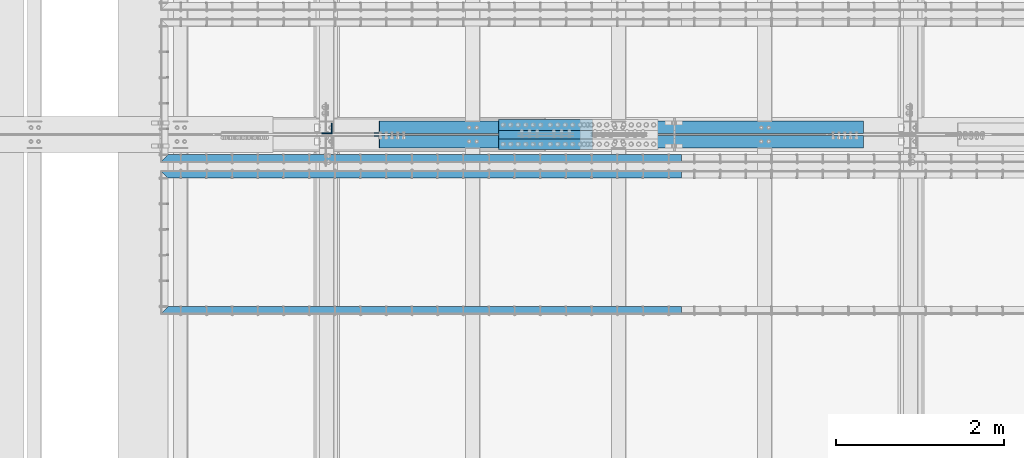
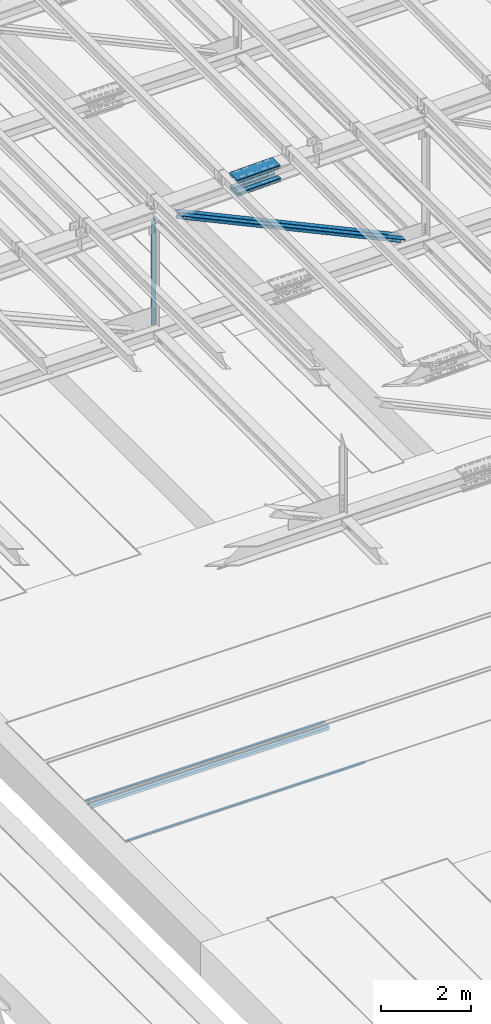
# One storey, part 1848 of 3843: 10 beams, 2 members, 7 elements without a shape of their own.
"""IFC2X3 building model written with IfcOpenShell, lengths in millimetres."""

from ifc_helpers import new_model, si_unit, frame, origin_with_axes, place, context, subcontext, project, spatial, faceted_brep, material, type_object, element, aggregate, save


model = new_model("IFC2X3")

# Units and contexts
model_context = context("Model", 3, precision=1e-05, world=origin_with_axes())
body_context = subcontext(model_context, "Body", "Model", "MODEL_VIEW")
ifc_project = project(units=[si_unit("LENGTHUNIT", "METRE", prefix="MILLI"), si_unit("AREAUNIT", "SQUARE_METRE"), si_unit("VOLUMEUNIT", "CUBIC_METRE"), si_unit("MASSUNIT", "GRAM", prefix="KILO"), si_unit("TIMEUNIT", "SECOND"), si_unit("PLANEANGLEUNIT", "RADIAN"), si_unit("SOLIDANGLEUNIT", "STERADIAN"), si_unit("THERMODYNAMICTEMPERATUREUNIT", "DEGREE_CELSIUS"), si_unit("LUMINOUSINTENSITYUNIT", "LUMEN")], contexts=[model_context])

# Site, building, storey
site_placement = place(None, origin_with_axes())
site = spatial("IfcSite", under=ifc_project, at=site_placement, CompositionType="ELEMENT")
building_placement = place(site_placement, origin_with_axes())
building = spatial("IfcBuilding", under=site, at=building_placement, Name="Undefined", CompositionType="ELEMENT")
storey_placement = place(building_placement, origin_with_axes())
storey = spatial("IfcBuildingStorey", under=building, at=storey_placement, Name="Undefined", CompositionType="ELEMENT", Elevation=0.0)

# Assembly, beam
assembly_1_placement = place(storey_placement, origin_with_axes())
assembly_1 = element("IfcElementAssembly", 1, at=assembly_1_placement, inside=storey, Name="EMBED_ANGLE", AssemblyPlace="NOTDEFINED", PredefinedType="RIGID_FRAME")
ifc_material_1 = material(Name="STEEL/A36")
beam_type_1 = type_object("IfcBeamType", Name="L3-1/2X3-1/2X5/16", PredefinedType="NOTDEFINED")
beam_1_placement = place(assembly_1_placement, frame((53207.412390625, 58632.3439999965, 30410.15), z_axis=(0.0, 0.0, -1.0), x_axis=(-1.0, 0.0, 0.0)))
beam_1 = element("IfcBeam", 2, at=beam_1_placement, type_object=beam_type_1, material=ifc_material_1, Name="EMBED_ANGLE", ObjectType="L3-1/2X3-1/2X5/16", context=body_context, shape_type="Brep", body=[
    faceted_brep([(-3.63797880709171e-12, 44.4499999999971, -44.4500000000007), (-3.63797880709171e-12, 44.4499999999971, 44.4500000000007), (6096.0, 44.4499999999971, 44.4500000000007), (6096.0, 44.4499999999971, -44.4500000000007), (-3.63797880709171e-12, 36.5124999999971, 44.4500000000007), (6103.9375, 36.5124999999971, 44.4500000000007), (-3.63797880709171e-12, 36.5124999999971, -36.5125000000007), (6103.9375, 36.5124999999971, -36.5125000000007), (3.63797880709171e-12, -44.4499999999971, -36.5125000000007), (6184.89999999999, -44.4499999999971, -36.5125000000007), (3.63797880709171e-12, -44.4499999999971, -44.4500000000007), (6184.89999999999, -44.4499999999971, -44.4500000000007)], [[[0, 1, 2, 3]], [[1, 4, 5, 2]], [[4, 6, 7, 5]], [[6, 8, 9, 7]], [[8, 10, 11, 9]], [[10, 0, 3, 11]], [[5, 7, 9, 11, 3, 2]], [[10, 8, 6, 4, 1, 0]]]),
])
aggregate(assembly_1, [beam_1])

assembly_2_placement = place(storey_placement, origin_with_axes())
assembly_2 = element("IfcElementAssembly", 3, at=assembly_2_placement, inside=storey, Name="EMBED_ANGLE", AssemblyPlace="NOTDEFINED", PredefinedType="RIGID_FRAME")
beam_2_placement = place(assembly_2_placement, frame((53207.4119790039, 56829.325, 30410.15), z_axis=(0.0, 0.0, -1.0), x_axis=(-1.0, 0.0, 0.0)))
beam_2 = element("IfcBeam", 4, at=beam_2_placement, type_object=beam_type_1, material=ifc_material_1, Name="EMBED_ANGLE", ObjectType="L3-1/2X3-1/2X5/16", context=body_context, shape_type="Brep", body=[
    faceted_brep([(-3.63797880709171e-12, 44.4499999999971, -44.4500000000007), (-3.63797880709171e-12, 44.4499999999971, 44.4500000000007), (6096.0, 44.4499999999971, 44.4500000000007), (6096.0, 44.4499999999971, -44.4500000000007), (-3.63797880709171e-12, 36.5124999999971, 44.4500000000007), (6103.9375, 36.5124999999971, 44.4500000000007), (-3.63797880709171e-12, 36.5124999999971, -36.5125000000007), (6103.9375, 36.5124999999971, -36.5125000000007), (3.63797880709171e-12, -44.4499999999971, -36.5125000000007), (6184.89999999999, -44.4499999999971, -36.5125000000007), (3.63797880709171e-12, -44.4499999999971, -44.4500000000007), (6184.89999999999, -44.4499999999971, -44.4500000000007)], [[[0, 1, 2, 3]], [[1, 4, 5, 2]], [[4, 6, 7, 5]], [[6, 8, 9, 7]], [[8, 10, 11, 9]], [[10, 0, 3, 11]], [[5, 7, 9, 11, 3, 2]], [[10, 8, 6, 4, 1, 0]]]),
])
aggregate(assembly_2, [beam_2])

assembly_3_placement = place(storey_placement, origin_with_axes())
assembly_3 = element("IfcElementAssembly", 5, at=assembly_3_placement, inside=storey, Name="EMBED_ANGLE", AssemblyPlace="NOTDEFINED", PredefinedType="RIGID_FRAME")
beam_3_placement = place(assembly_3_placement, frame((47022.5119790039, 58442.606, 30410.15), z_axis=(0.0, 0.0, -1.0), x_axis=(1.0, 0.0, 0.0)))
beam_3 = element("IfcBeam", 6, at=beam_3_placement, type_object=beam_type_1, material=ifc_material_1, Name="EMBED_ANGLE", ObjectType="L3-1/2X3-1/2X5/16", context=body_context, shape_type="Brep", body=[
    faceted_brep([(88.8999999971129, 44.4500000000007, -44.4499999999971), (88.8999999965163, 44.4499999999971, 44.4500000000007), (6184.90000000001, 44.4499999999971, 44.4500000000007), (6184.90000000001, 44.4499999999971, -44.4500000000007), (80.9624999965163, 36.5124999999971, 44.4500000000007), (6184.90000000001, 36.5124999999971, 44.4500000000007), (80.9624999971129, 36.5125000000007, -36.5124999999971), (6184.90000000001, 36.5124999999971, -36.5125000000007), (3.63797880709171e-12, -44.4499999999971, -36.5125000000007), (6184.89999999999, -44.4499999999971, -36.5125000000007), (3.63797880709171e-12, -44.4499999999971, -44.4500000000007), (6184.89999999999, -44.4499999999971, -44.4500000000007)], [[[0, 1, 2, 3]], [[1, 4, 5, 2]], [[4, 6, 7, 5]], [[6, 8, 9, 7]], [[8, 10, 11, 9]], [[10, 0, 3, 11]], [[5, 7, 9, 11, 3, 2]], [[10, 8, 6, 4, 1, 0]]]),
])
aggregate(assembly_3, [beam_3])

# Assembly, beams
assembly_4_placement = place(storey_placement, origin_with_axes())
assembly_4 = element("IfcElementAssembly", 7, at=assembly_4_placement, inside=storey, Name="BEAM", AssemblyPlace="NOTDEFINED", PredefinedType="RIGID_FRAME")
ifc_material_2 = material(Name="STEEL/A572-50")
beam_type_2 = type_object("IfcBeamType", PredefinedType="NOTDEFINED")
beam_4_placement = place(assembly_4_placement, frame((51036.3155330324, 59029.6, 45745.1992940111), z_axis=(0.0, -1.0, 0.0), x_axis=(0.999699385122672, 0.0, 0.0245181440030071)))
beam_4 = element("IfcBeam", 8, at=beam_4_placement, type_object=beam_type_2, material=ifc_material_2, Name="PLATE", context=body_context, shape_type="Brep", body=[
    faceted_brep([(-4.36557456851006e-11, 12.7000000000116, -63.5), (-4.36557456851006e-11, 12.7000000000116, 63.5), (1104.90907094938, 12.6999999984037, 63.5), (1104.90907094938, 12.6999999984037, -63.5), (1.45519152283669e-11, -12.700000000008, 63.5), (1104.90907094934, -12.7000000015032, 63.5), (1.45519152283669e-11, -12.700000000008, -63.5), (1104.90907094934, -12.7000000015032, -63.5)], [[[0, 1, 2, 3]], [[1, 4, 5, 2]], [[4, 6, 7, 5]], [[6, 0, 3, 7]], [[5, 7, 3, 2]], [[6, 4, 1, 0]]]),
])
beam_5_placement = place(assembly_4_placement, frame((51036.3155330324, 58801.0, 45745.1992940111), z_axis=(0.0, -1.0, 0.0), x_axis=(0.999699385122672, 0.0, 0.0245181440030071)))
beam_5 = element("IfcBeam", 9, at=beam_5_placement, type_object=beam_type_2, material=ifc_material_2, Name="PLATE", context=body_context, shape_type="Brep", body=[
    faceted_brep([(-4.36557456851006e-11, 12.7000000000116, -63.5), (-4.36557456851006e-11, 12.7000000000116, 63.5), (1104.90907094938, 12.6999999984037, 63.5), (1104.90907094938, 12.6999999984037, -63.5), (1.45519152283669e-11, -12.700000000008, 63.5), (1104.90907094934, -12.7000000015032, 63.5), (1.45519152283669e-11, -12.700000000008, -63.5), (1104.90907094934, -12.7000000015032, -63.5)], [[[0, 1, 2, 3]], [[1, 4, 5, 2]], [[4, 6, 7, 5]], [[6, 0, 3, 7]], [[5, 7, 3, 2]], [[6, 4, 1, 0]]]),
])
beam_6_placement = place(assembly_4_placement, frame((51043.5640563281, 58801.0, 45450.0189870714), z_axis=(0.0, -1.0, 0.0), x_axis=(0.999699385122672, 0.0, 0.0245181440030071)))
beam_6 = element("IfcBeam", 10, at=beam_6_placement, type_object=beam_type_2, material=ifc_material_2, Name="PLATE", context=body_context, shape_type="Brep", body=[
    faceted_brep([(-4.36557456851006e-11, 12.7000000000116, -63.5), (-4.36557456851006e-11, 12.7000000000116, 63.5), (1104.90000001677, 12.7000000017251, 63.5), (1104.90000001677, 12.7000000017251, -63.5), (1.45519152283669e-11, -12.700000000008, 63.5), (1104.90000001682, -12.6999999982909, 63.5), (1.45519152283669e-11, -12.700000000008, -63.5), (1104.90000001682, -12.6999999982909, -63.5)], [[[0, 1, 2, 3]], [[1, 4, 5, 2]], [[4, 6, 7, 5]], [[6, 0, 3, 7]], [[5, 7, 3, 2]], [[6, 4, 1, 0]]]),
])
beam_7_placement = place(assembly_4_placement, frame((51043.5640563281, 59029.6, 45450.0189870714), z_axis=(0.0, -1.0, 0.0), x_axis=(0.999699385122672, 0.0, 0.0245181440030071)))
beam_7 = element("IfcBeam", 11, at=beam_7_placement, type_object=beam_type_2, material=ifc_material_2, Name="PLATE", context=body_context, shape_type="Brep", body=[
    faceted_brep([(-4.36557456851006e-11, 12.7000000000116, -63.5), (-4.36557456851006e-11, 12.7000000000116, 63.5), (1104.90000001677, 12.7000000017251, 63.5), (1104.90000001677, 12.7000000017251, -63.5), (1.45519152283669e-11, -12.700000000008, 63.5), (1104.90000001682, -12.6999999982909, 63.5), (1.45519152283669e-11, -12.700000000008, -63.5), (1104.90000001682, -12.6999999982909, -63.5)], [[[0, 1, 2, 3]], [[1, 4, 5, 2]], [[4, 6, 7, 5]], [[6, 0, 3, 7]], [[5, 7, 3, 2]], [[6, 4, 1, 0]]]),
])
beam_type_3 = type_object("IfcBeamType", PredefinedType="NOTDEFINED")
beam_8_placement = place(assembly_4_placement, frame((52139.372556607, 58915.3, 45834.2616105658), z_axis=(0.0, -1.0, 0.0), x_axis=(-0.999699385122672, 0.0, -0.024518144003004)))
beam_8 = element("IfcBeam", 12, at=beam_8_placement, type_object=beam_type_3, material=ifc_material_2, Name="PLATE", context=body_context, shape_type="Brep", body=[
    faceted_brep([(-1.45519152283669e-11, 12.7000000000025, -177.800000000003), (-1.45519152283669e-11, 12.7000000000025, 177.800000000003), (1104.90000001682, 12.7000000017051, 177.800000000003), (1104.90000001682, 12.7000000017051, -177.800000000003), (4.36557456851006e-11, -12.7000000000171, 177.800000000003), (1104.90000001686, -12.6999999983072, 177.800000000003), (4.36557456851006e-11, -12.7000000000171, -177.800000000003), (1104.90000001686, -12.6999999983072, -177.800000000003)], [[[0, 1, 2, 3]], [[1, 4, 5, 2]], [[4, 6, 7, 5]], [[6, 0, 3, 7]], [[5, 7, 3, 2]], [[6, 4, 1, 0]]]),
])
beam_9_placement = place(assembly_4_placement, frame((52149.6526513255, 58915.3, 45415.215263873), z_axis=(0.0, -1.0, 0.0), x_axis=(-0.999699385122672, 0.0, -0.024518144003004)))
beam_9 = element("IfcBeam", 13, at=beam_9_placement, type_object=beam_type_3, material=ifc_material_2, Name="PLATE", context=body_context, shape_type="Brep", body=[
    faceted_brep([(-1.45519152283669e-11, 12.7000000000025, -177.800000000003), (-1.45519152283669e-11, 12.7000000000025, 177.800000000003), (1104.90000001682, 12.7000000017051, 177.800000000003), (1104.90000001682, 12.7000000017051, -177.800000000003), (4.36557456851006e-11, -12.7000000000171, 177.800000000003), (1104.90000001686, -12.6999999983072, 177.800000000003), (4.36557456851006e-11, -12.7000000000171, -177.800000000003), (1104.90000001686, -12.6999999983072, -177.800000000003)], [[[0, 1, 2, 3]], [[1, 4, 5, 2]], [[4, 6, 7, 5]], [[6, 0, 3, 7]], [[5, 7, 3, 2]], [[6, 4, 1, 0]]]),
])
aggregate(assembly_4, [beam_4, beam_5, beam_6, beam_8, beam_9, beam_7])

# Assembly, beam
assembly_5_placement = place(storey_placement, origin_with_axes())
assembly_5 = element("IfcElementAssembly", 14, at=assembly_5_placement, inside=storey, Name="ANGLE", AssemblyPlace="NOTDEFINED", PredefinedType="RIGID_FRAME")
beam_type_4 = type_object("IfcBeamType", Name="L5X5X3/8", PredefinedType="NOTDEFINED")
beam_10_placement = place(assembly_5_placement, frame((48996.6, 58988.325, 45546.8867572636), z_axis=(-1.0, 0.0, 0.0), x_axis=(0.0, 0.0, -1.0)))
beam_10 = element("IfcBeam", 15, at=beam_10_placement, type_object=beam_type_4, material=ifc_material_2, Name="ANGLE", ObjectType="L5X5X3/8", context=body_context, shape_type="Brep", body=[
    faceted_brep([(223.459240537923, 63.5, -63.5), (223.459240537923, 63.5, 63.5), (3028.1730929709, 63.5, 63.5), (3028.1730929709, 63.5, -63.5), (223.459240537923, 53.9749999999985, 63.5), (3028.1730929709, 53.9749999999985, 63.5), (223.459240537923, 53.9749999999985, -53.9749999999985), (3028.1730929709, 53.9749999999985, -53.9749999999985), (223.459240537923, -63.5, -53.9749999999985), (3028.1730929709, -63.5, -53.9749999999985), (223.459240537923, -63.5, -63.5), (3028.1730929709, -63.5, -63.5)], [[[0, 1, 2, 3]], [[1, 4, 5, 2]], [[4, 6, 7, 5]], [[6, 8, 9, 7]], [[8, 10, 11, 9]], [[10, 0, 3, 11]], [[5, 7, 9, 11, 3, 2]], [[10, 8, 6, 4, 1, 0]]]),
])
aggregate(assembly_5, [beam_10])

# Assembly, member
assembly_6_placement = place(storey_placement, origin_with_axes())
assembly_6 = element("IfcElementAssembly", 16, at=assembly_6_placement, inside=storey, Name="ANGLE", AssemblyPlace="NOTDEFINED", PredefinedType="RIGID_FRAME")
member_type = type_object("IfcMemberType", Name="L6X6X1/2", PredefinedType="NOTDEFINED")
member_1_placement = place(assembly_6_placement, frame((48996.6000000179, 59001.025, 45546.8867572636), z_axis=(-0.420689214779442, 0.0, -0.907204819524376), x_axis=(0.907204819524377, 0.0, -0.420689214779442)))
member_1 = element("IfcMember", 17, at=member_1_placement, type_object=member_type, material=ifc_material_2, Name="ANGLE", ObjectType="L6X6X1/2", context=body_context, shape_type="Brep", body=[
    faceted_brep([(654.73262605285, 76.1999999999971, -76.2000000005428), (654.73262605285, 76.1999999999971, 76.1999999991604), (6984.91433398184, 76.1999999999971, 76.1999999925392), (6984.91433398184, 76.1999999999971, -76.2000000071639), (654.73262605285, 63.5, 76.1999999991604), (6984.91433398184, 63.5, 76.1999999925392), (654.732626052843, 63.5, -63.5000000005675), (6984.91433398184, 63.5, -63.5000000071814), (654.732626052843, -76.1999999999971, -63.5000000005675), (6984.91433398184, -76.1999999999971, -63.5000000071814), (654.73262605285, -76.1999999999971, -76.2000000005428), (6984.91433398184, -76.1999999999971, -76.2000000071639)], [[[0, 1, 2, 3]], [[1, 4, 5, 2]], [[4, 6, 7, 5]], [[6, 8, 9, 7]], [[8, 10, 11, 9]], [[10, 0, 3, 11]], [[5, 7, 9, 11, 3, 2]], [[10, 8, 6, 4, 1, 0]]]),
])
aggregate(assembly_6, [member_1])

assembly_7_placement = place(storey_placement, origin_with_axes())
assembly_7 = element("IfcElementAssembly", 18, at=assembly_7_placement, inside=storey, Name="ANGLE", AssemblyPlace="NOTDEFINED", PredefinedType="RIGID_FRAME")
member_2_placement = place(assembly_7_placement, frame((55930.7999990969, 58829.575, 42331.3580378311), z_axis=(-0.420689214779442, 0.0, -0.907204819524376), x_axis=(-0.907204819524375, 0.0, 0.420689214779444)))
member_2 = element("IfcMember", 19, at=member_2_placement, type_object=member_type, material=ifc_material_2, Name="ANGLE", ObjectType="L6X6X1/2", context=body_context, shape_type="Brep", body=[
    faceted_brep([(658.563576777346, 76.1999999999971, -76.1999999991531), (658.563576777349, 76.1999999999971, 76.2000000005355), (6988.74528470634, 76.1999999999971, 76.2000000071639), (6988.74528470634, 76.1999999999971, -76.1999999925392), (658.563576777349, 63.5, 76.2000000005355), (6988.74528470634, 63.5, 76.2000000071639), (658.563576777353, 63.5, -63.4999999991851), (6988.74528470634, 63.5, -63.4999999925567), (658.563576777353, -76.1999999999971, -63.4999999991851), (6988.74528470634, -76.1999999999971, -63.4999999925567), (658.563576777346, -76.1999999999971, -76.1999999991531), (6988.74528470634, -76.1999999999971, -76.1999999925392)], [[[0, 1, 2, 3]], [[1, 4, 5, 2]], [[4, 6, 7, 5]], [[6, 8, 9, 7]], [[8, 10, 11, 9]], [[10, 0, 3, 11]], [[5, 7, 9, 11, 3, 2]], [[10, 8, 6, 4, 1, 0]]]),
])
aggregate(assembly_7, [member_2])

save(model, "model.ifc")
